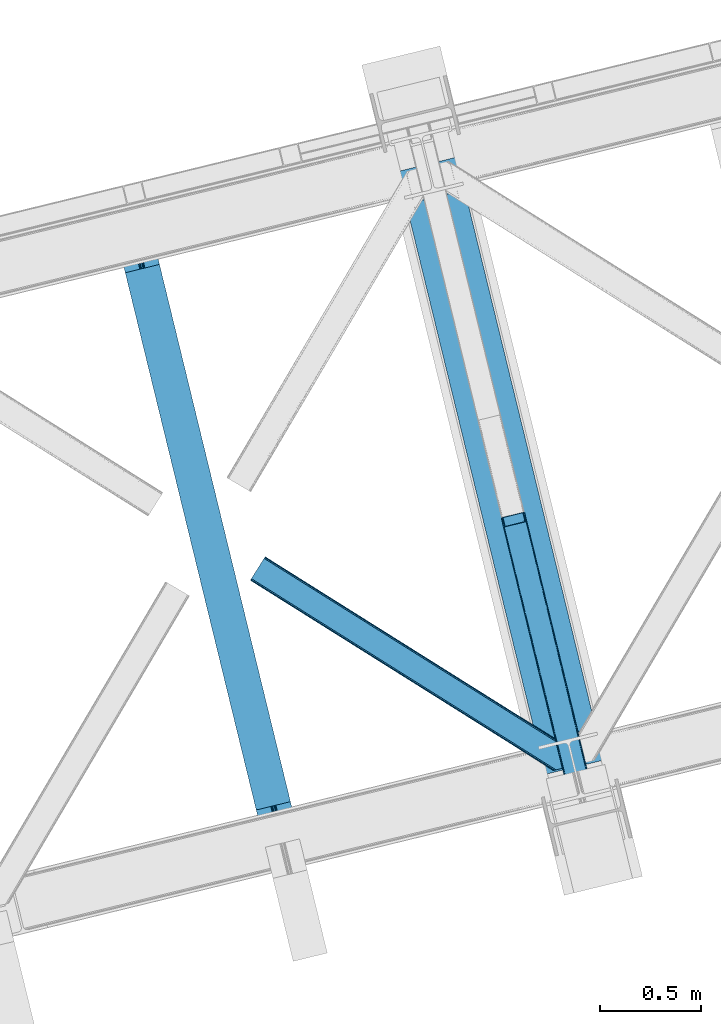
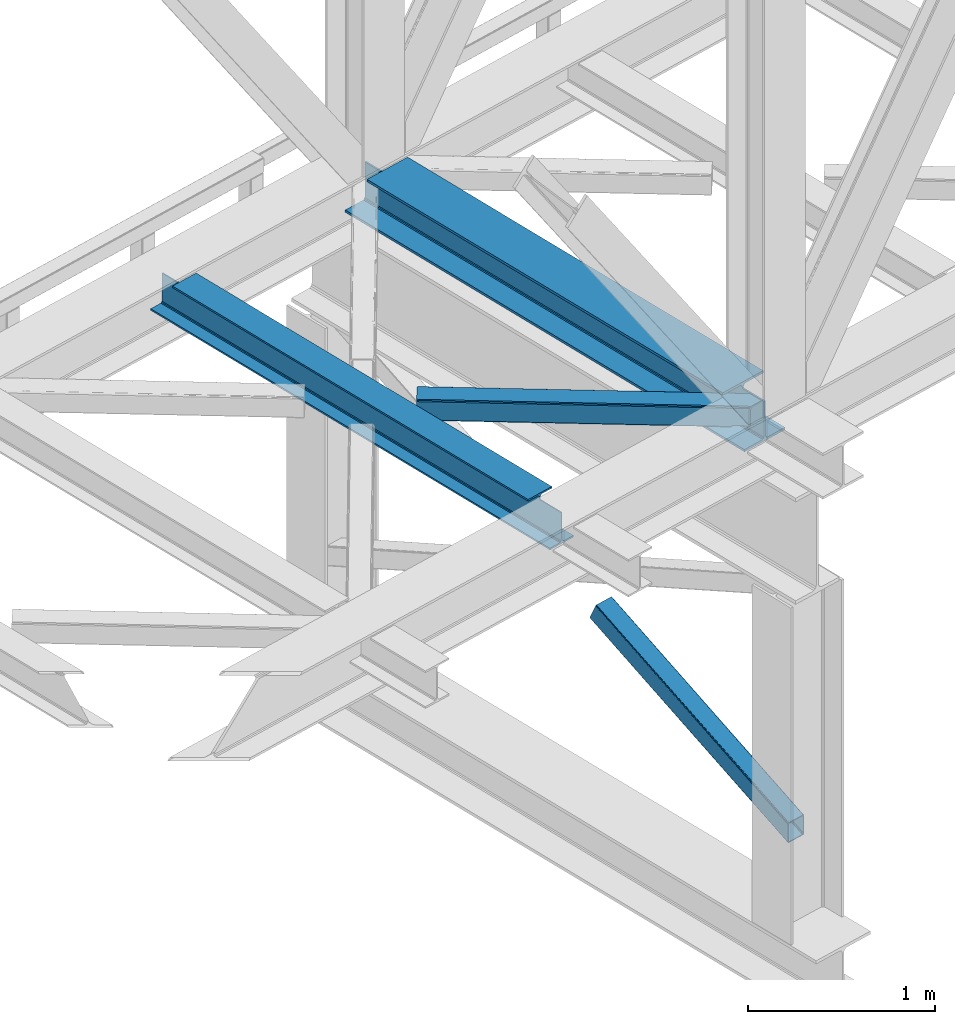
# One storey, part 29 of 92: 2 beams, 2 members.
"""IFC4 building model written with IfcOpenShell, lengths in millimetres."""

from ifc_helpers import new_model, entity, si_unit, converted_unit, derived_unit, direction, frame, origin, place, context, subcontext, project, spatial, triangles, polygons, material, type_object, element, save


model = new_model("IFC4")

# Units and contexts
model_context = context("Model", 3, precision=0.01, world=origin(), true_north=direction((6.12303176911189e-17, 1.0)))
plan_context = context("Plan", 3, precision=0.01, world=origin(), true_north=direction((6.12303176911189e-17, 1.0)))
body_context = subcontext(model_context, "Body", "Model", "MODEL_VIEW")
ifc_project = project(units=[si_unit("LENGTHUNIT", "METRE", prefix="MILLI"), si_unit("AREAUNIT", "SQUARE_METRE"), si_unit("VOLUMEUNIT", "CUBIC_METRE"), converted_unit("PLANEANGLEUNIT", "DEGREE", entity("IfcRatioMeasure", 0.0174532925199433), si_unit("PLANEANGLEUNIT", "RADIAN"), dimensions=[0, 0, 0, 0, 0, 0, 0]), si_unit("MASSUNIT", "GRAM", prefix="KILO"), derived_unit("MASSDENSITYUNIT", [(si_unit("MASSUNIT", "GRAM", prefix="KILO"), 1), (si_unit("LENGTHUNIT", "METRE"), -3)]), derived_unit("MOMENTOFINERTIAUNIT", [(si_unit("LENGTHUNIT", "METRE"), 4)]), si_unit("TIMEUNIT", "SECOND"), si_unit("FREQUENCYUNIT", "HERTZ"), si_unit("THERMODYNAMICTEMPERATUREUNIT", "DEGREE_CELSIUS"), derived_unit("THERMALTRANSMITTANCEUNIT", [(si_unit("MASSUNIT", "GRAM", prefix="KILO"), 1), (si_unit("THERMODYNAMICTEMPERATUREUNIT", "KELVIN"), -1), (si_unit("TIMEUNIT", "SECOND"), -3)]), derived_unit("VOLUMETRICFLOWRATEUNIT", [(si_unit("LENGTHUNIT", "METRE"), 3), (si_unit("TIMEUNIT", "SECOND"), -1)]), derived_unit("MASSFLOWRATEUNIT", [(si_unit("MASSUNIT", "GRAM", prefix="KILO"), 1), (si_unit("TIMEUNIT", "SECOND"), -1)]), derived_unit("ROTATIONALFREQUENCYUNIT", [(si_unit("TIMEUNIT", "SECOND"), -1)]), si_unit("ELECTRICCURRENTUNIT", "AMPERE"), si_unit("ELECTRICVOLTAGEUNIT", "VOLT"), si_unit("POWERUNIT", "WATT"), si_unit("FORCEUNIT", "NEWTON", prefix="KILO"), si_unit("ILLUMINANCEUNIT", "LUX"), si_unit("LUMINOUSFLUXUNIT", "LUMEN"), si_unit("LUMINOUSINTENSITYUNIT", "CANDELA"), derived_unit("USERDEFINED", [(si_unit("MASSUNIT", "GRAM", prefix="KILO"), -1), (si_unit("LENGTHUNIT", "METRE"), -2), (si_unit("TIMEUNIT", "SECOND"), 3), (si_unit("LUMINOUSFLUXUNIT", "LUMEN"), 1)]), derived_unit("LINEARVELOCITYUNIT", [(si_unit("LENGTHUNIT", "METRE"), 1), (si_unit("TIMEUNIT", "SECOND"), -1)]), si_unit("PRESSUREUNIT", "PASCAL"), derived_unit("USERDEFINED", [(si_unit("LENGTHUNIT", "METRE"), -2), (si_unit("MASSUNIT", "GRAM", prefix="KILO"), 1), (si_unit("TIMEUNIT", "SECOND"), -2)]), derived_unit("LINEARFORCEUNIT", [(si_unit("MASSUNIT", "GRAM", prefix="KILO"), 1), (si_unit("LENGTHUNIT", "METRE"), 1), (si_unit("TIMEUNIT", "SECOND"), -2), (si_unit("LENGTHUNIT", "METRE"), -1)]), derived_unit("PLANARFORCEUNIT", [(si_unit("MASSUNIT", "GRAM", prefix="KILO"), 1), (si_unit("LENGTHUNIT", "METRE"), 1), (si_unit("TIMEUNIT", "SECOND"), -2), (si_unit("LENGTHUNIT", "METRE"), -2)])], contexts=[model_context, plan_context])

# Site, building, storey
site_placement = place(None, origin())
site = spatial("IfcSite", under=ifc_project, at=site_placement, CompositionType="ELEMENT")
building_placement = place(site_placement, origin())
building = spatial("IfcBuilding", under=site, at=building_placement, CompositionType="ELEMENT")
storey_placement = place(building_placement, frame((0.0, 0.0, 15900.0)))
storey = spatial("IfcBuildingStorey", under=building, at=storey_placement, Name="05", CompositionType="ELEMENT", Elevation=15900.0)

# Beams
ifc_material = material(Name="Metal painted (White)")
beam_type = type_object("IfcBeamType", PredefinedType="BEAM")
beam_1_placement = place(storey_placement, frame((-56721.23, 3960.3, 3441.0)))
element("IfcBeam", 1, at=beam_1_placement, inside=storey, type_object=beam_type, material=ifc_material, ObjectType="Steel Beam", PredefinedType="BEAM", context=body_context, shape_type="Tessellation", body=[
    polygons([(900.985346189432, 41.4445662733087, 11.000000000004), (900.985346189432, 41.4445662733087, 2.16573425859679e-12), (170.021610174752, 3040.13999372697, 2.16573425859679e-12), (170.021610174752, 3040.13999372697, 11.000000000004), (834.919806235814, 25.3403919499662, 11.000000000004), (103.956070221135, 3024.03581940363, 11.000000000004), (828.971056214522, 23.8903211957401, 12.2179274798217), (98.0073201998427, 3022.5857486494, 12.2179274798217), (823.927949458422, 22.6610105689194, 15.6862915010192), (92.9642134437254, 3021.35643802258, 15.6862915010192), (820.558253255237, 21.8396114687119, 20.8770650821657), (89.5945172405581, 3020.53503892237, 20.8770650821657), (819.374973305543, 21.5511744621206, 27.0000000000047), (88.4112372908723, 3020.24660191578, 27.0000000000047), (81.6103728838801, 3018.58881926485, 27.0000000000047), (81.6103728838801, 3018.58881926485, 203.000000000006), (88.4112372908636, 3020.24660191578, 203.000000000006), (-8.66293703438714e-12, 2998.69542745366, 2.16573425859679e-12), (-8.66293703438714e-12, 2998.69542745366, 10.9999999999997), (66.0655399536172, 3014.799601777, 11.000000000004), (72.0142899749097, 3016.24967253123, 12.2179274798217), (77.0573967310183, 3017.47898315805, 15.6862915010192), (80.4270929341942, 3018.30038225826, 20.8770650821657), (819.374973305543, 21.5511744621195, 203.000000000006), (812.574108898559, 19.8933918111881, 203.000000000006), (812.574108898559, 19.8933918111881, 27.0000000000047), (811.390828948873, 19.6049548045968, 20.8770650821657), (808.021132745689, 18.7835557043887, 15.6862915010192), (802.978025989589, 17.5542450775691, 12.2179274798217), (797.029275968279, 16.1041743233431, 11.000000000004), (730.963736014671, -1.08286712929839e-12, 10.9999999999997), (730.963736014662, 0.0, 2.16573425859679e-12), (779.675212882749, 184.415062601691, 203.069791966819), (128.020401343495, 2857.75452019162, 203.000000000006), (128.243282132641, 2856.84017775719, 203.617301946336), (128.256196377177, 2856.7871977843, 217.000003693143), (779.530009633815, 185.010597404071, 217.000003676718), (779.530880241713, 185.007025963191, 204.00000679514), (772.964911718311, 182.385463974442, 203.006342981529), (772.742064056773, 183.299815969774, 203.617301946336), (772.729149812254, 183.352795942667, 217.000003693143), (121.455336555599, 2855.1293963229, 217.000003676718), (121.45446594771, 2855.13296776378, 204.00000679514), (121.310166358655, 2855.72494066435, 203.076120467494), (121.219536936503, 2856.09673754069, 203.000000000006), (780.71349435786, 185.298194377514, 223.122939328039), (784.08249076653, 186.122464201393, 228.313710402595), (789.125126170554, 187.353708426698, 231.782072735464), (795.073705041258, 188.80448128138, 232.999999602236), (861.139155906781, 204.909021065315, 232.999999283132), (861.137682570343, 204.915065042187, 243.999994005812), (691.116301666422, 163.469558245298, 243.999994827032), (691.117775002877, 163.463514268424, 233.000000104353), (757.183225868383, 179.568054052358, 232.999999785253), (763.132130996713, 181.017488520583, 231.782072861016), (768.175695503853, 182.244921343717, 228.313710479427), (771.546082413585, 183.063487001147, 223.12293937232), (120.271851831572, 2854.84179934945, 223.122939328039), (116.902855422893, 2854.01752952557, 228.313710402595), (111.860220018869, 2852.78628530027, 231.782072735464), (105.911641148157, 2851.33551244559, 232.999999602236), (39.8461902826332, 2835.23097266165, 232.999999283128), (39.8476636190708, 2835.22492868478, 243.999994005812), (209.869044522992, 2876.67043548167, 243.999994827032), (209.867571186554, 2876.67647945854, 233.000000104357), (143.802120321031, 2860.57193967461, 232.999999785253), (137.853215192701, 2859.12250520638, 231.782072861012), (132.809650685561, 2857.89507238325, 228.313710479427), (129.43926377583, 2857.07650672582, 223.12293937232)], [[[1, 2, 3, 4]], [[5, 1, 4, 6]], [[7, 5, 6, 8]], [[9, 7, 8, 10]], [[11, 9, 10, 12]], [[13, 11, 12, 14]], [[15, 16, 17, 14, 12, 10, 8, 6, 4, 3, 18, 19, 20, 21, 22, 23]], [[13, 24, 25, 26, 27, 28, 29, 30, 31, 32, 2, 1, 5, 7, 9, 11]], [[2, 32, 18, 3]], [[32, 31, 19, 18]], [[31, 30, 20, 19]], [[27, 26, 15, 23]], [[28, 27, 23, 22]], [[29, 28, 22, 21]], [[30, 29, 21, 20]], [[33, 24, 13, 14, 17, 34, 35, 36, 37, 38]], [[25, 39, 40, 41, 42, 43, 44, 16, 15, 26]], [[39, 25, 24, 33]], [[45, 34, 17, 16]], [[41, 40, 38, 37, 46, 47, 48, 49, 50, 51, 52, 53, 54, 55, 56, 57]], [[42, 58, 59, 60, 61, 62, 63, 64, 65, 66, 67, 68, 69, 36, 35, 43]], [[46, 37, 36, 69]], [[47, 46, 69, 68]], [[48, 47, 68, 67]], [[49, 48, 67, 66]], [[50, 49, 66, 65]], [[51, 50, 65, 64]], [[52, 51, 64, 63]], [[53, 52, 63, 62]], [[54, 53, 62, 61]], [[55, 54, 61, 60]], [[56, 55, 60, 59]], [[57, 56, 59, 58]], [[41, 57, 58, 42]]], closed=False),
])
beam_2_placement = place(storey_placement, frame((-55324.63, 4300.74, 3385.0)))
element("IfcBeam", 2, at=beam_2_placement, inside=storey, type_object=beam_type, material=ifc_material, ObjectType="Steel Beam", PredefinedType="BEAM", context=body_context, shape_type="Tessellation", body=[
    polygons([(1022.42935345713, 71.0478278971016, 15.4999999999986), (1022.42935345713, 71.0478278971016, 0.0), (291.465617442446, 3069.74325535076, 0.0), (291.465617442446, 3069.74325535076, 15.4999999999986), (899.042242073153, 40.9709140873286, 15.4999999999986), (168.078506058482, 3039.66634154099, 15.4999999999986), (892.349898299199, 39.3395844888243, 16.8701684147963), (161.38616228452, 3038.03501194248, 16.8701684147963), (886.676403198583, 37.956610033653, 20.7720779386413), (155.712667183904, 3036.65203748731, 20.7720779386413), (882.885494970008, 37.0325360459184, 26.6116982174294), (151.921758955329, 3035.72796349958, 26.6116982174294), (881.554305026603, 36.7080444135029, 33.500000000001), (150.590569011941, 3035.40347186716, 33.500000000001), (140.875048430531, 3033.03521093726, 33.500000000001), (140.875048430514, 3033.03521093726, 259.000000000002), (150.590569011924, 3035.40347186716, 259.000000000002), (8.66293703438714e-12, 2998.69542745366, 0.0), (8.66293703438714e-12, 2998.69542745366, 15.4999999999986), (123.387111383972, 3028.77234126343, 15.4999999999986), (130.079455157918, 3030.40367086194, 16.8701684147963), (135.752950258551, 3031.78664531711, 20.7720779386413), (139.543858487126, 3032.71071930484, 26.6116982174294), (881.554305026603, 36.7080444135024, 259.000000000002), (871.838784445193, 34.3397834836003, 259.000000000002), (871.838784445193, 34.3397834836003, 33.500000000001), (870.507594501796, 34.0152918511848, 26.6116982174294), (866.716686273221, 33.0912178634502, 20.7720779386413), (861.043191172614, 31.7082434082778, 16.8701684147963), (854.350847398652, 30.0769138097741, 15.4999999999986), (730.963736014679, 1.08286712929839e-12, 15.4999999999986), (730.963736014679, 0.0, 0.0), (841.85453458624, 199.57193011123, 259.069791776412), (190.199733064564, 2872.911390143, 259.000000000002), (190.423126166404, 2871.99494573803, 259.61730333112), (190.43551501003, 2871.94412150426, 266.500003008253), (841.70935577274, 200.167408132524, 266.500002998871), (841.709705893492, 200.16597182779, 260.000004007589), (832.229597305445, 196.831858094285, 259.006343172366), (832.006227290704, 197.748309612731, 259.61730333112), (831.993838447078, 197.799133846505, 266.500003008253), (180.719997684385, 2869.57584721824, 266.500002998871), (180.719647563633, 2869.57728352297, 260.000004007589), (180.574841905289, 2870.17133233676, 259.07612046749), (180.484212483145, 2870.5431292131, 259.000000000002), (843.040843642659, 200.49067757721, 273.388305639783), (846.831120231363, 201.417342749123, 279.227924098781), (852.504191178893, 202.802057212799, 283.129832400619), (859.196382860027, 204.434010743612, 284.500000377228), (982.583411547879, 234.511263798724, 284.500000138971), (982.58174174121, 234.518113867455, 299.999995328161), (691.11631964394, 163.469484603413, 299.999995890962), (691.1179894506, 163.462634534682, 284.500000701776), (814.505018138444, 193.539887589793, 284.500000463519), (821.197505034592, 195.170630056372, 283.129832461069), (826.871416683343, 196.551895700897, 279.227924137322), (830.662951470344, 197.473399350194, 273.388305663684), (179.388509814458, 2869.25257777355, 273.388305639783), (175.598233225771, 2868.32591260164, 279.227924098781), (169.925162278232, 2866.94119813796, 283.129832400619), (163.232970597099, 2865.30924460715, 284.500000377228), (39.8459419092461, 2835.23199155204, 284.500000138971), (39.8476117159065, 2835.22514148331, 299.999995328161), (331.313033813185, 2906.27377074735, 299.999995890962), (331.311364006534, 2906.28062081608, 284.500000701776), (207.924335318681, 2876.20336776097, 284.500000463519), (201.231848422542, 2874.57262529439, 283.129832461069), (195.557936773773, 2873.19135964987, 279.227924137322), (191.76640198679, 2872.26985600057, 273.388305663684)], [[[1, 2, 3, 4]], [[5, 1, 4, 6]], [[7, 5, 6, 8]], [[9, 7, 8, 10]], [[11, 9, 10, 12]], [[13, 11, 12, 14]], [[15, 16, 17, 14, 12, 10, 8, 6, 4, 3, 18, 19, 20, 21, 22, 23]], [[13, 24, 25, 26, 27, 28, 29, 30, 31, 32, 2, 1, 5, 7, 9, 11]], [[2, 32, 18, 3]], [[32, 31, 19, 18]], [[31, 30, 20, 19]], [[27, 26, 15, 23]], [[28, 27, 23, 22]], [[29, 28, 22, 21]], [[30, 29, 21, 20]], [[33, 24, 13, 14, 17, 34, 35, 36, 37, 38]], [[25, 39, 40, 41, 42, 43, 44, 16, 15, 26]], [[39, 25, 24, 33]], [[45, 34, 17, 16]], [[41, 40, 38, 37, 46, 47, 48, 49, 50, 51, 52, 53, 54, 55, 56, 57]], [[42, 58, 59, 60, 61, 62, 63, 64, 65, 66, 67, 68, 69, 36, 35, 43]], [[46, 37, 36, 69]], [[47, 46, 69, 68]], [[48, 47, 68, 67]], [[49, 48, 67, 66]], [[50, 49, 66, 65]], [[51, 50, 65, 64]], [[52, 51, 64, 63]], [[53, 52, 63, 62]], [[54, 53, 62, 61]], [[55, 54, 61, 60]], [[56, 55, 60, 59]], [[57, 56, 59, 58]], [[41, 57, 58, 42]]], closed=False),
])

# Members
member_type_1 = type_object("IfcMemberType", PredefinedType="BRACE")
member_1_placement = place(storey_placement, frame((-54811.65, 4087.91, 911.28)))
element("IfcMember", 3, at=member_1_placement, inside=storey, type_object=member_type_1, ObjectType="Steel Vertical Brace", PredefinedType="BRACE", context=body_context, shape_type="Tessellation", body=[
    triangles([(109.104968261723, 1516.67719116211, 692.224026489257), (472.287451171876, 26.7611572265623, 0.0), (369.303039550781, 1.65774765014658, 0.0), (6.12055664062791, 1491.57349090576, 692.224026489257), (115.806884765625, 1516.48185424805, 696.163320922849), (116.588232421876, 1515.53714447022, 698.605032348631), (479.087036132813, 28.4189048767093, 7.68092651366896), (114.113964843753, 1517.03007659912, 694.092517089841), (478.091748046878, 28.1761871337894, 4.96481323242188), (111.760620117188, 1517.09867706299, 692.710043334959), (477.096459960943, 27.9334693908695, 2.24986267089844), (474.691955566406, 27.3474586486818, 1.12551269531104), (126.913183593751, 1473.16763763428, 795.217739868163), (479.087036132813, 28.4189048767093, 123.979641723632), (123.345959472659, 1469.55913696289, 801.112728881835), (120.797277832033, 1468.71151428223, 801.59758300781), (472.287451171876, 26.7611572265623, 131.659405517577), (125.406298828129, 1470.70383453369, 799.729092407226), (474.691955566406, 27.3474586486818, 130.53505554199), (126.657385253908, 1471.97061767578, 797.659451293945), (477.096459960943, 27.9334693908695, 129.409542846679), (478.091748046878, 28.1761871337894, 126.694592285156), (369.303039550781, 1.65774765014658, 131.659405517577), (17.8128662109375, 1443.60839538574, 801.59758300781), (10.3296020507842, 1444.74844207764, 795.217739868163), (362.503454589845, 0.0, 123.979641723632), (363.498742675787, 0.242717742919922, 126.694592285156), (11.1062988281265, 1443.8037322998, 797.659451293945), (364.494030761722, 0.485435485839844, 129.409542846679), (12.8038696289077, 1443.25550994873, 799.729092407226), (366.898535156251, 1.07144622802753, 130.53505554199), (15.1572143554731, 1443.18690948486, 801.112728881835), (0.0, 1487.11794891357, 698.605032348631), (362.503454589845, 0.0, 7.68092651366896), (366.898535156251, 1.07144622802753, 1.12551269531104), (3.56722412109957, 1490.72644958496, 692.710043334959), (364.494030761722, 0.485435485839844, 2.24986267089844), (1.51153564453125, 1489.58175201416, 694.092517089841), (363.498742675787, 0.242717742919922, 4.96481323242188), (0.25579833984375, 1488.31496887207, 696.163320922849), (112.216406250001, 1512.35419921875, 703.161730957028), (111.439709472659, 1513.29890899658, 700.720019531247), (109.742138671878, 1513.84713134766, 698.650378417966), (104.733142089848, 1513.49482727051, 696.781887817382), (107.388793945313, 1513.91631317139, 697.266741943356), (120.062438964844, 1471.51773834229, 795.172393798828), (121.569323730473, 1473.98212280273, 790.661041259766), (121.313525390629, 1472.78510284424, 793.102752685547), (118.002099609381, 1470.37362213135, 796.55486755371), (115.453417968754, 1469.52599945068, 797.040884399412), (6.85539550781687, 1488.76784820557, 698.650378417966), (5.60430908203125, 1487.50048370361, 700.720019531247), (11.4644165039063, 1490.75958709717, 696.781887817382), (8.91573486328707, 1489.9119644165, 697.266741943356), (5.34385986328562, 1486.30346374512, 703.161730957028), (17.1756958007827, 1446.43787384033, 795.172393798828), (19.5290405273481, 1446.36927337646, 796.55486755371), (15.4781250000015, 1446.98667755127, 793.102752685547), (22.1846923828125, 1446.79075927734, 797.040884399412), (14.7014282226592, 1447.9313873291, 790.661041259766), (371.754052734381, 2.25567626953125, 125.048181152342), (374.158557128911, 2.8419776916503, 126.173693847653), (369.349548339844, 1.66966552734357, 123.923831176755), (367.358972167975, 1.18393936157236, 118.492767333984), (368.354260253909, 1.42665710449228, 121.208880615231), (472.236291503912, 26.7492393493649, 123.923831176755), (467.427282714845, 25.5772178649904, 126.173693847653), (469.831787109375, 26.1632286071781, 125.048181152342), (473.236230468756, 26.9922477722166, 121.208880615231), (474.23151855469, 27.2349655151365, 118.492767333984), (369.349548339844, 1.66966552734357, 7.73557434081886), (371.754052734381, 2.25567626953125, 6.61122436523146), (367.358972167975, 1.18393936157236, 13.166638183593), (368.354260253909, 1.42665710449228, 10.4505249023423), (374.158557128911, 2.8419776916503, 5.48571166992042), (472.236291503912, 26.7492393493649, 7.73557434081886), (473.236230468756, 26.9922477722166, 10.4505249023423), (469.831787109375, 26.1632286071781, 6.61122436523146), (474.23151855469, 27.2349655151365, 13.166638183593), (467.427282714845, 25.5772178649904, 5.48571166992042)], [[1, 2, 3], [3, 4, 1], [5, 6, 7], [8, 5, 9], [10, 8, 11], [1, 10, 12], [12, 2, 1], [11, 12, 10], [9, 11, 8], [7, 9, 5], [6, 13, 14], [14, 7, 6], [15, 16, 17], [18, 15, 19], [20, 18, 21], [13, 20, 22], [22, 14, 13], [21, 22, 20], [19, 21, 18], [17, 19, 15], [17, 16, 23], [24, 23, 16], [25, 26, 27], [28, 27, 29], [30, 29, 31], [32, 31, 23], [23, 24, 32], [31, 32, 30], [29, 30, 28], [27, 28, 25], [25, 33, 26], [34, 26, 33], [4, 3, 35], [36, 35, 37], [38, 37, 39], [40, 39, 34], [34, 33, 40], [39, 40, 38], [37, 38, 36], [35, 36, 4], [41, 6, 42], [43, 5, 8], [8, 10, 43], [6, 41, 13], [6, 5, 43], [43, 42, 6], [44, 1, 4], [1, 45, 43], [44, 45, 1], [1, 43, 10], [18, 46, 15], [47, 13, 41], [46, 20, 13], [48, 13, 47], [20, 46, 18], [46, 16, 15], [13, 48, 46], [46, 49, 16], [16, 50, 24], [50, 16, 49], [51, 33, 52], [4, 53, 44], [54, 4, 51], [4, 54, 53], [51, 4, 36], [55, 52, 33], [36, 38, 51], [40, 51, 38], [55, 33, 25], [40, 33, 51], [56, 32, 24], [57, 56, 24], [58, 25, 56], [59, 24, 50], [24, 59, 57], [30, 32, 56], [25, 60, 55], [28, 56, 25], [60, 25, 58], [56, 28, 30], [61, 62, 23], [27, 63, 31], [27, 31, 29], [23, 62, 17], [23, 31, 61], [63, 61, 31], [64, 26, 34], [26, 65, 63], [64, 65, 26], [26, 63, 27], [19, 66, 22], [67, 17, 62], [68, 19, 17], [68, 17, 67], [22, 21, 19], [66, 14, 22], [19, 68, 66], [66, 69, 14], [14, 70, 7], [70, 14, 69], [71, 35, 72], [34, 73, 64], [74, 34, 71], [34, 74, 73], [71, 34, 39], [72, 3, 75], [71, 39, 35], [35, 39, 37], [75, 3, 2], [35, 3, 72], [76, 9, 7], [77, 76, 7], [78, 12, 76], [79, 7, 70], [7, 79, 77], [12, 9, 76], [2, 80, 75], [12, 78, 2], [80, 2, 78], [11, 9, 12], [80, 44, 75], [53, 75, 44], [44, 80, 78], [45, 78, 76], [43, 76, 77], [42, 77, 79], [79, 41, 42], [77, 42, 43], [76, 43, 45], [78, 45, 44], [47, 41, 70], [79, 70, 41], [47, 70, 69], [48, 69, 66], [46, 66, 68], [49, 68, 67], [67, 50, 49], [68, 49, 46], [66, 46, 48], [69, 48, 47], [50, 67, 59], [62, 59, 67], [57, 59, 62], [56, 57, 61], [58, 56, 63], [60, 58, 65], [65, 64, 60], [63, 65, 58], [61, 63, 56], [62, 61, 57], [55, 60, 64], [64, 73, 55], [52, 55, 73], [51, 52, 74], [54, 51, 71], [53, 54, 72], [72, 75, 53], [71, 72, 54], [74, 71, 51], [73, 74, 52]]),
])
member_type_2 = type_object("IfcMemberType", PredefinedType="BRACE")
member_2_placement = place(storey_placement, frame((-56060.0, 4319.82, 3511.0)))
element("IfcMember", 4, at=member_2_placement, inside=storey, type_object=member_type_2, ObjectType="Steel Horizontal Brace", PredefinedType="BRACE", context=body_context, shape_type="Tessellation", body=[
    triangles([(9.30640869140188, 960.453584289551, 0.0), (65.1262573242202, 1049.387109375, 0.0), (1387.64088134765, 219.293300628662, 0.0), (1423.32242431641, 72.9304321289064, 0.0), (1428.81511230468, 50.3934356689451, 10.8028289794929), (1429.26624755859, 48.5365722656252, 17.5000946044929), (0.0, 945.631233215332, 17.5000946044929), (0.711584472657705, 946.759652709961, 10.8028289794929), (1427.52681884765, 55.6814849853517, 5.12526855468968), (2.72541503905813, 949.972828674317, 5.12526855468968), (1425.59670410156, 63.5952461242678, 1.33247680664135), (5.74383544921875, 954.781256103515, 1.33247680664135), (68.6841796875015, 1055.05943756104, 1.33247680664135), (71.7026000976548, 1059.86786499023, 5.12526855468968), (1383.45043945313, 236.497483062744, 5.17061462402489), (73.7210815429644, 1063.08104095459, 10.8028289794929), (1388.24084472656, 238.005821228027, 10.8028289794929), (1390.04538574219, 238.445619964599, 17.5000946044929), (74.4280151367202, 1064.20946044922, 17.5000946044929), (1385.3666015625, 228.628195953369, 1.33247680664135), (1383.37137451172, 236.818393707275, 17.5198608398459), (1390.04538574219, 238.445619964599, 18.5197998046897), (1384.34340820312, 237.055007171631, 18.5197998046897), (1385.65030517578, 231.698357391358, 18.5197998046897), (1570.05300292969, 125.462400054932, 18.5197998046897), (1572.78771972656, 114.236631774902, 18.5197998046897), (1570.05300292969, 125.462400054932, 122.500662231447), (74.4280151367202, 1064.20946044922, 122.500662231447), (1570.50413818359, 123.605536651611, 129.197927856447), (73.7210815429644, 1063.08104095459, 129.197927856447), (1571.79708251953, 118.317487335205, 134.874325561526), (71.7026000976548, 1059.86786499023, 134.874325561526), (1573.72254638671, 110.403726196289, 138.667117309571), (68.6841796875015, 1055.05943756104, 138.667117309571), (1576.00147705078, 101.068540191651, 139.999594116212), (65.1262573242202, 1049.387109375, 139.999594116212), (67.9818969726548, 1053.93915710449, 12.1260040283232), (1385.8177368164, 226.784703826905, 12.1260040283232), (1384.56665039063, 231.905321502685, 17.5198608398459), (70.0003784179644, 1057.15175170898, 17.8035644531265), (1572.43425292968, 115.704856109619, 24.4996673583992), (70.7073120117202, 1058.28017120361, 24.4996673583992), (1387.7478515625, 218.870942687989, 8.3320495605476), (64.9634765625015, 1049.13014831543, 8.3320495605476), (1390.02213134766, 209.53575668335, 6.99957275390625), (61.4055541992202, 1043.45782012939, 6.99957275390625), (13.0271118164019, 966.382292175293, 6.99957275390625), (1420.9411743164, 82.6879760742186, 6.99957275390625), (1425.14556884766, 65.4390289306639, 12.1260040283232), (1426.39665527343, 60.3184112548824, 17.5198608398459), (1423.21545410156, 73.3527900695799, 8.3320495605476), (1572.43425292968, 115.704856109619, 115.501089477541), (70.7073120117202, 1058.28017120361, 115.501089477541), (1576.10379638672, 100.646182250976, 131.667544555665), (1578.37807617187, 91.3109962463377, 133.000021362306), (61.4055541992202, 1043.45782012939, 133.000021362306), (64.9634765625015, 1049.13014831543, 131.667544555665), (1574.17368164063, 108.560234069824, 127.87475280762), (67.9818969726548, 1053.93915710449, 127.87475280762), (1572.88538818359, 113.847992706299, 122.196029663086), (70.0003784179644, 1057.15175170898, 122.196029663086), (1595.3630859375, 21.6376327514645, 133.000021362306), (1595.3630859375, 21.6376327514645, 139.999594116212), (9.30640869140188, 960.453584289551, 139.999594116212), (1530.30659179687, 5.77958908081018, 139.999594116212), (1521.23272705078, 3.56780548095685, 138.667117309571), (5.74383544921875, 954.781256103515, 138.667117309571), (1513.54017333984, 1.69291992187482, 134.874325561526), (2.72541503905813, 949.972828674317, 134.874325561526), (1508.40095214843, 0.440089416503724, 129.197927856447), (0.711584472657705, 946.759652709961, 129.197927856447), (1506.59641113281, 0.0, 122.500662231447), (0.0, 945.631233215332, 122.500662231447), (1430.48012695312, 47.7738281250004, 18.5197998046897), (1506.59641113281, 0.0, 18.5197998046897), (1427.74541015625, 58.9995964050295, 18.5197998046897), (1517.50737304687, 2.65972137451172, 18.5197998046897), (3.72535400390188, 951.560522460937, 24.4996673583992), (1516.07955322265, 2.31206817626935, 24.4996673583992), (4.43228759765771, 952.688360595703, 17.8035644531265), (1427.07103271484, 59.6591491699219, 18.0198303222678), (6.45076904296729, 955.901536560059, 12.1260040283232), (9.46453857421875, 960.710545349121, 8.3320495605476), (6.45076904296729, 955.901536560059, 127.87475280762), (13.0271118164019, 966.382292175293, 133.000021362306), (9.46453857421875, 960.710545349121, 131.667544555665), (3.72535400390188, 951.560522460937, 115.501089477541), (4.43228759765771, 952.688360595703, 122.196029663086), (1530.71586914062, 5.87958297729529, 131.667544555665), (1523.02331542969, 4.00469741821325, 127.87475280762), (1517.88409423828, 2.75186691284216, 122.196029663086), (1539.78973388672, 8.09165725708044, 133.000021362306), (1516.07955322265, 2.31206817626935, 115.501089477541)], [[1, 2, 3], [3, 4, 1], [5, 6, 7], [7, 8, 5], [9, 5, 8], [8, 10, 9], [11, 9, 10], [10, 12, 11], [4, 11, 12], [12, 1, 4], [13, 14, 15], [16, 17, 15], [15, 14, 16], [18, 17, 19], [16, 19, 17], [20, 3, 2], [2, 13, 20], [15, 20, 13], [18, 21, 17], [18, 22, 23], [17, 21, 15], [21, 18, 23], [24, 22, 25], [22, 24, 23], [25, 26, 24], [25, 22, 27], [19, 22, 18], [22, 28, 27], [19, 28, 22], [29, 27, 30], [28, 30, 27], [31, 29, 32], [30, 32, 29], [33, 31, 34], [32, 34, 31], [35, 33, 36], [34, 36, 33], [37, 38, 39], [39, 40, 37], [24, 41, 42], [24, 26, 41], [42, 40, 39], [43, 38, 44], [37, 44, 38], [45, 43, 46], [44, 46, 43], [46, 47, 45], [48, 45, 47], [3, 48, 4], [43, 20, 38], [39, 15, 21], [15, 39, 38], [38, 20, 15], [43, 3, 20], [3, 45, 48], [43, 45, 3], [9, 49, 50], [50, 5, 9], [6, 5, 50], [49, 11, 51], [51, 4, 48], [4, 51, 11], [49, 9, 11], [41, 52, 53], [53, 42, 41], [54, 55, 56], [56, 57, 54], [58, 54, 57], [57, 59, 58], [60, 58, 59], [59, 61, 60], [52, 60, 61], [61, 53, 52], [58, 31, 33], [58, 33, 54], [55, 54, 35], [60, 31, 58], [62, 55, 63], [35, 63, 55], [54, 33, 35], [29, 31, 60], [25, 27, 52], [41, 25, 52], [25, 41, 26], [29, 60, 27], [60, 52, 27], [64, 35, 36], [35, 64, 65], [63, 35, 65], [66, 65, 64], [64, 67, 66], [68, 66, 67], [67, 69, 68], [70, 68, 69], [69, 71, 70], [72, 70, 71], [71, 73, 72], [74, 72, 6], [74, 75, 72], [73, 6, 72], [73, 7, 6], [74, 76, 77], [77, 75, 74], [78, 79, 76], [76, 80, 78], [76, 81, 80], [79, 77, 76], [50, 82, 80], [50, 49, 82], [51, 48, 83], [47, 83, 48], [49, 51, 82], [83, 82, 51], [16, 37, 40], [42, 28, 19], [16, 40, 19], [16, 14, 37], [40, 42, 19], [37, 14, 13], [46, 2, 1], [2, 44, 13], [44, 2, 46], [44, 37, 13], [30, 59, 32], [53, 28, 42], [28, 61, 30], [61, 28, 53], [30, 61, 59], [36, 56, 64], [34, 32, 59], [59, 57, 34], [57, 56, 36], [36, 34, 57], [82, 12, 10], [1, 47, 46], [1, 83, 47], [83, 1, 12], [82, 83, 12], [78, 7, 73], [8, 80, 82], [10, 8, 82], [80, 8, 7], [78, 80, 7], [67, 84, 69], [64, 56, 85], [85, 86, 64], [86, 84, 67], [67, 64, 86], [71, 69, 84], [73, 87, 78], [88, 73, 71], [73, 88, 87], [88, 71, 84], [89, 65, 66], [90, 66, 68], [91, 68, 70], [92, 63, 65], [89, 66, 90], [62, 63, 92], [89, 92, 65], [91, 90, 68], [72, 93, 91], [93, 72, 75], [79, 75, 77], [75, 79, 93], [72, 91, 70], [85, 55, 92], [85, 56, 55], [55, 62, 92], [91, 93, 88], [87, 88, 93], [90, 91, 84], [88, 84, 91], [89, 90, 86], [84, 86, 90], [92, 89, 85], [86, 85, 89], [93, 79, 78], [78, 87, 93]]),
])

save(model, "model.ifc")
